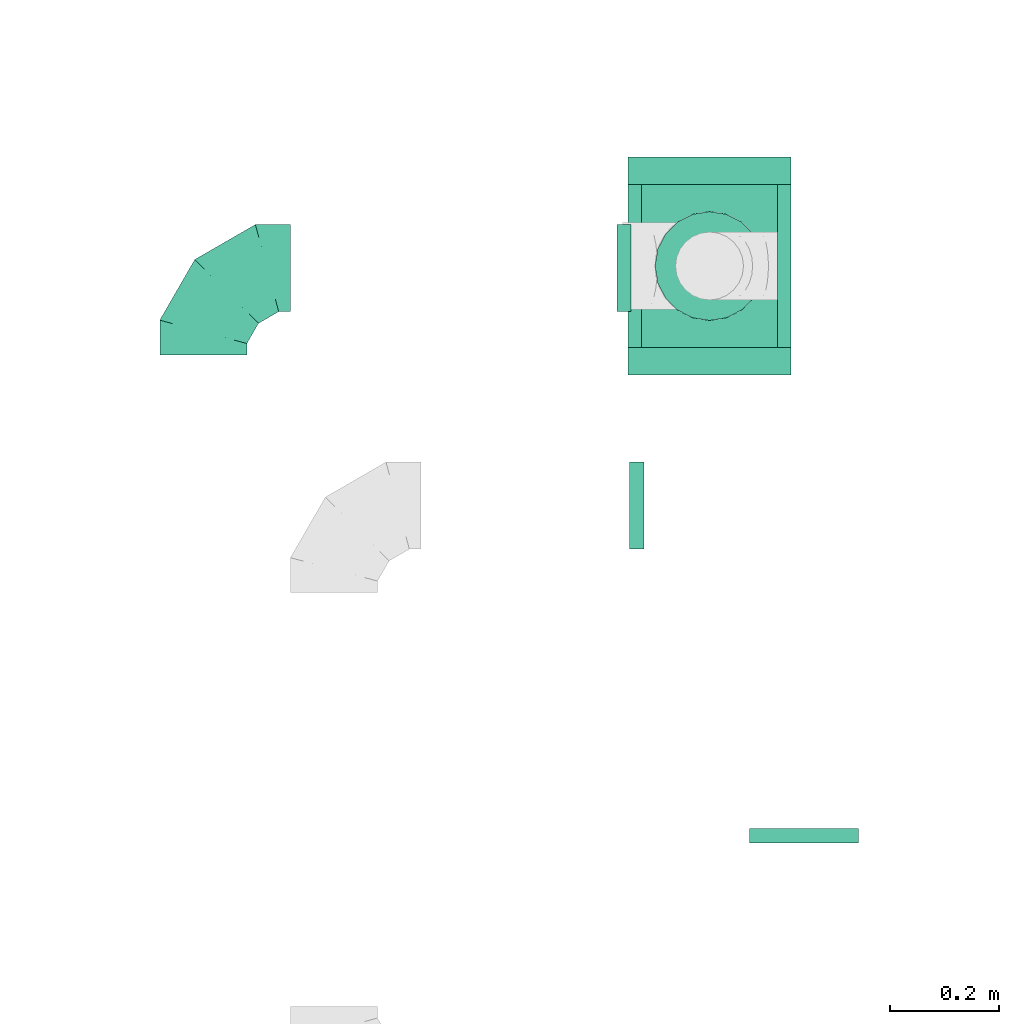
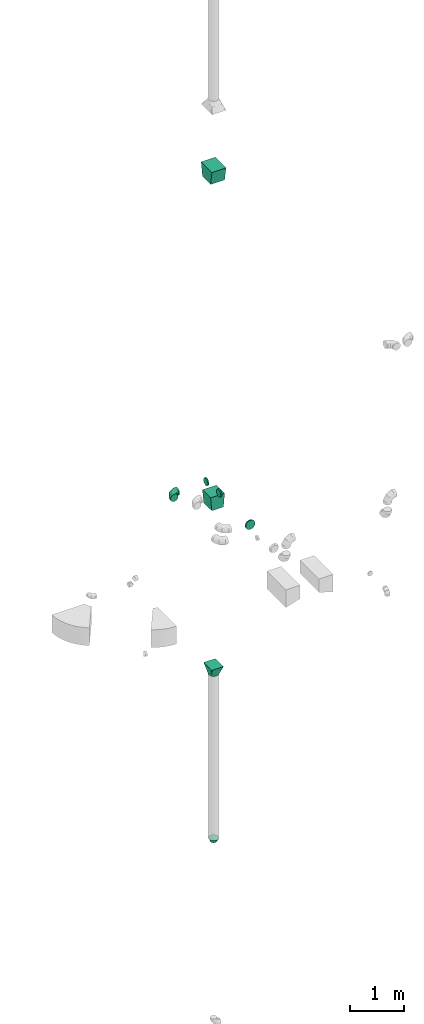
# One storey, part 3 of 32: 8 flow fittings.
"""IFC2X3 building model written with IfcOpenShell, lengths in millimetres."""

from ifc_helpers import new_model, entity, si_unit, converted_unit, derived_unit, direction, frame, origin, place, context, subcontext, project, spatial, polyline, outline, extrude, faceted_brep, source, transform, mapped, material, type_object, type_shapes, element, save


model = new_model("IFC2X3")

# Units and contexts
model_context = context("Model", 3, precision=0.01, world=origin(), true_north=direction((6.12303176911189e-17, 1.0)))
body_context = subcontext(model_context, "Body", "Model", "MODEL_VIEW")
ifc_project = project(units=[si_unit("LENGTHUNIT", "METRE", prefix="MILLI"), si_unit("AREAUNIT", "SQUARE_METRE"), si_unit("VOLUMEUNIT", "CUBIC_METRE"), converted_unit("PLANEANGLEUNIT", "DEGREE", entity("IfcRatioMeasure", 0.0174532925199433), si_unit("PLANEANGLEUNIT", "RADIAN"), dimensions=[0, 0, 0, 0, 0, 0, 0]), si_unit("MASSUNIT", "GRAM", prefix="KILO"), derived_unit("MASSDENSITYUNIT", [(si_unit("MASSUNIT", "GRAM", prefix="KILO"), 1), (si_unit("LENGTHUNIT", "METRE"), -3)]), derived_unit("MOMENTOFINERTIAUNIT", [(si_unit("LENGTHUNIT", "METRE"), 4)]), si_unit("TIMEUNIT", "SECOND"), si_unit("FREQUENCYUNIT", "HERTZ"), si_unit("THERMODYNAMICTEMPERATUREUNIT", "DEGREE_CELSIUS"), derived_unit("THERMALTRANSMITTANCEUNIT", [(si_unit("MASSUNIT", "GRAM", prefix="KILO"), 1), (si_unit("THERMODYNAMICTEMPERATUREUNIT", "KELVIN"), -1), (si_unit("TIMEUNIT", "SECOND"), -3)]), derived_unit("VOLUMETRICFLOWRATEUNIT", [(si_unit("LENGTHUNIT", "METRE"), 3), (si_unit("TIMEUNIT", "SECOND"), -1)]), derived_unit("MASSFLOWRATEUNIT", [(si_unit("MASSUNIT", "GRAM", prefix="KILO"), 1), (si_unit("TIMEUNIT", "SECOND"), -1)]), derived_unit("ROTATIONALFREQUENCYUNIT", [(si_unit("TIMEUNIT", "SECOND"), -1)]), si_unit("ELECTRICCURRENTUNIT", "AMPERE"), si_unit("ELECTRICVOLTAGEUNIT", "VOLT"), si_unit("POWERUNIT", "WATT"), si_unit("FORCEUNIT", "NEWTON", prefix="KILO"), si_unit("ILLUMINANCEUNIT", "LUX"), si_unit("LUMINOUSFLUXUNIT", "LUMEN"), si_unit("LUMINOUSINTENSITYUNIT", "CANDELA"), derived_unit("USERDEFINED", [(si_unit("MASSUNIT", "GRAM", prefix="KILO"), -1), (si_unit("LENGTHUNIT", "METRE"), -2), (si_unit("TIMEUNIT", "SECOND"), 3), (si_unit("LUMINOUSFLUXUNIT", "LUMEN"), 1)]), derived_unit("LINEARVELOCITYUNIT", [(si_unit("LENGTHUNIT", "METRE"), 1), (si_unit("TIMEUNIT", "SECOND"), -1)]), si_unit("PRESSUREUNIT", "PASCAL"), derived_unit("USERDEFINED", [(si_unit("LENGTHUNIT", "METRE"), -2), (si_unit("MASSUNIT", "GRAM", prefix="KILO"), 1), (si_unit("TIMEUNIT", "SECOND"), -2)]), derived_unit("LINEARFORCEUNIT", [(si_unit("MASSUNIT", "GRAM", prefix="KILO"), 1), (si_unit("LENGTHUNIT", "METRE"), 1), (si_unit("TIMEUNIT", "SECOND"), -2), (si_unit("LENGTHUNIT", "METRE"), -1)]), derived_unit("PLANARFORCEUNIT", [(si_unit("MASSUNIT", "GRAM", prefix="KILO"), 1), (si_unit("LENGTHUNIT", "METRE"), 1), (si_unit("TIMEUNIT", "SECOND"), -2), (si_unit("LENGTHUNIT", "METRE"), -2)])], contexts=[model_context])

# Site, building, storey
site_placement = place(None, origin())
site = spatial("IfcSite", under=ifc_project, at=site_placement, CompositionType="ELEMENT")
building_placement = place(site_placement, origin())
building = spatial("IfcBuilding", under=site, at=building_placement, CompositionType="ELEMENT")
storey_placement = place(building_placement, frame((0.0, 0.0, 8100.0)))
storey = spatial("IfcBuildingStorey", under=building, at=storey_placement, CompositionType="ELEMENT", Elevation=8100.0)

# Flow fittings
ifc_material = material()
duct_fitting_type_1 = type_object("IfcDuctFittingType", PredefinedType="NOTDEFINED", material=ifc_material)
shared_shape_1 = source(origin(), body_context, "Body", "SweptSolid", [
    extrude(outline(polyline([(-161.94, -137.02), (139.1, -137.02), (159.86, 112.11), (-137.02, 161.94), (-161.94, -137.02)])), frame((150.0, -150.0, 0.0), z_axis=(0.0, 1.0, 0.0), x_axis=(0.996545254853089, 0.0, -0.0830515203340174)), (0.0, 0.0, 1.0), 300.0),
])
type_shapes(duct_fitting_type_1, [shared_shape_1])
flow_fitting_1_placement = place(storey_placement, frame((8023.56, 14800.47, 3070.0), z_axis=(-1.0, 0.0, 0.0), x_axis=(0.0, 0.0, -1.0)))
element("IfcFlowFitting", 1, at=flow_fitting_1_placement, inside=storey, type_object=duct_fitting_type_1, material=ifc_material, context=body_context, shape_type="MappedRepresentation", body=[
    mapped(shared_shape_1, transform((0.0, 0.0, 0.0), scale=1.0)),
])
duct_fitting_type_2 = type_object("IfcDuctFittingType", PredefinedType="NOTDEFINED", material=ifc_material)
shared_shape_2 = source(origin(), body_context, "Body", "SweptSolid", [
    extrude(outline(polyline([(-123.3, -172.62), (180.84, -172.62), (115.08, 221.94), (-172.62, 123.3), (-123.3, -172.62)])), frame((150.0, 0.0, -150.0), z_axis=(0.0, 0.0, 1.0), x_axis=(0.986393923832143, -0.164398987305359, 0.0)), (0.0, 0.0, 1.0), 300.0),
])
type_shapes(duct_fitting_type_2, [shared_shape_2])
flow_fitting_2_placement = place(storey_placement, frame((8023.56, 14800.47, 10130.0), z_axis=(-1.0, 0.0, 0.0), x_axis=(0.0, 0.0, 1.0)))
element("IfcFlowFitting", 2, at=flow_fitting_2_placement, inside=storey, type_object=duct_fitting_type_2, material=ifc_material, context=body_context, shape_type="MappedRepresentation", body=[
    mapped(shared_shape_2, transform((0.0, 0.0, 0.0), scale=1.0)),
])
duct_fitting_type_3 = type_object("IfcDuctFittingType", PredefinedType="NOTDEFINED", material=ifc_material)
shared_shape_3 = source(origin(), body_context, "Body", "Brep", [
    faceted_brep([(-160.0, 0.0, -80.0), (-160.0, -20.71, -77.27), (-160.0, -40.0, -69.28), (-160.0, -56.57, -56.57), (-160.0, -69.28, -40.0), (-160.0, -77.27, -20.71), (-160.0, -80.0, 0.0), (-160.0, -77.27, 20.71), (-160.0, -69.28, 40.0), (-160.0, -56.57, 56.57), (-160.0, -40.0, 69.28), (-160.0, -20.71, 77.27), (-160.0, 0.0, 80.0), (-160.0, 20.71, 77.27), (-160.0, 40.0, 69.28), (-160.0, 56.57, 56.57), (-160.0, 69.28, 40.0), (-160.0, 77.27, 20.71), (-160.0, 80.0, 0.0), (-160.0, 77.27, -20.71), (-160.0, 69.28, -40.0), (-160.0, 56.57, -56.57), (-160.0, 40.0, -69.28), (-160.0, 20.71, -77.27), (-122.68, 20.71, 77.27), (-127.85, 40.0, 69.28), (-117.13, 0.0, 80.0), (-132.29, 56.57, 56.57), (-137.83, 77.27, 20.71), (-138.56, 80.0, 0.0), (-135.69, 69.28, 40.0), (-135.69, 69.28, -40.0), (-132.29, 56.57, -56.57), (-137.83, 77.27, -20.71), (-122.68, 20.71, -77.27), (-117.13, 0.0, -80.0), (-127.85, 40.0, -69.28), (-111.58, -20.71, -77.27), (-106.41, -40.0, -69.28), (-101.97, -56.57, -56.57), (-98.56, -69.28, -40.0), (-96.42, -77.27, -20.71), (-95.69, -80.0, 0.0), (-96.42, -77.27, 20.71), (-98.56, -69.28, 40.0), (-101.97, -56.57, 56.57), (-106.41, -40.0, 69.28), (-111.58, -20.71, 77.27), (-58.03, 58.03, 77.27), (-72.15, 72.15, 69.28), (-42.87, 42.87, 80.0), (-84.28, 84.28, 56.57), (-93.59, 93.59, 40.0), (-99.44, 99.44, 20.71), (-101.44, 101.44, 0.0), (-99.44, 99.44, -20.71), (-93.59, 93.59, -40.0), (-84.28, 84.28, -56.57), (-58.03, 58.03, -77.27), (-42.87, 42.87, -80.0), (-72.15, 72.15, -69.28), (-27.71, 27.71, -77.27), (-13.59, 13.59, -69.28), (-1.46, 1.46, -56.57), (7.85, -7.85, -40.0), (13.7, -13.7, -20.71), (15.69, -15.69, 0.0), (13.7, -13.7, 20.71), (7.85, -7.85, 40.0), (-1.46, 1.46, 56.57), (-13.59, 13.59, 69.28), (-27.71, 27.71, 77.27), (-20.71, 122.68, 77.27), (-40.0, 127.85, 69.28), (0.0, 117.13, 80.0), (-56.57, 132.29, 56.57), (-69.28, 135.69, 40.0), (-77.27, 137.83, 20.71), (-80.0, 138.56, 0.0), (-77.27, 137.83, -20.71), (-69.28, 135.69, -40.0), (-56.57, 132.29, -56.57), (-20.71, 122.68, -77.27), (0.0, 117.13, -80.0), (-40.0, 127.85, -69.28), (20.71, 111.58, -77.27), (40.0, 106.41, -69.28), (56.57, 101.97, -56.57), (69.28, 98.56, -40.0), (77.27, 96.42, -20.71), (80.0, 95.69, 0.0), (77.27, 96.42, 20.71), (69.28, 98.56, 40.0), (56.57, 101.97, 56.57), (40.0, 106.41, 69.28), (20.71, 111.58, 77.27), (-20.71, 160.0, -77.27), (-40.0, 160.0, -69.28), (-56.57, 160.0, -56.57), (-69.28, 160.0, -40.0), (-77.27, 160.0, -20.71), (-80.0, 160.0, 0.0), (-77.27, 160.0, 20.71), (-69.28, 160.0, 40.0), (-56.57, 160.0, 56.57), (-40.0, 160.0, 69.28), (-20.71, 160.0, 77.27), (0.0, 160.0, 80.0), (20.71, 160.0, 77.27), (40.0, 160.0, 69.28), (56.57, 160.0, 56.57), (69.28, 160.0, 40.0), (77.27, 160.0, 20.71), (80.0, 160.0, 0.0), (77.27, 160.0, -20.71), (69.28, 160.0, -40.0), (56.57, 160.0, -56.57), (40.0, 160.0, -69.28), (20.71, 160.0, -77.27), (0.0, 160.0, -80.0)], [[[0, 1, 2, 3, 4, 5, 6, 7, 8, 9, 10, 11, 12, 13, 14, 15, 16, 17, 18, 19, 20, 21, 22, 23]], [[24, 25, 14, 13]], [[26, 24, 13, 12]], [[14, 25, 27, 15]], [[28, 29, 18, 17]], [[30, 28, 17, 16]], [[15, 27, 30, 16]], [[20, 31, 32, 21]], [[33, 31, 20, 19]], [[18, 29, 33, 19]], [[34, 35, 0, 23]], [[36, 34, 23, 22]], [[32, 36, 22, 21]], [[1, 0, 35, 37]], [[2, 1, 37, 38]], [[3, 2, 38, 39]], [[5, 4, 40, 41]], [[6, 5, 41, 42]], [[39, 40, 4, 3]], [[6, 42, 43, 7]], [[7, 43, 44, 8]], [[8, 44, 45, 9]], [[9, 45, 46, 10]], [[10, 46, 47, 11]], [[26, 12, 11, 47]], [[48, 49, 25, 24]], [[50, 48, 24, 26]], [[27, 25, 49, 51]], [[52, 53, 28, 30]], [[51, 52, 30, 27]], [[29, 28, 53, 54]], [[55, 56, 31, 33]], [[54, 55, 33, 29]], [[32, 31, 56, 57]], [[58, 59, 35, 34]], [[60, 58, 34, 36]], [[57, 60, 36, 32]], [[37, 35, 59, 61]], [[38, 37, 61, 62]], [[39, 38, 62, 63]], [[41, 40, 64, 65]], [[42, 41, 65, 66]], [[63, 64, 40, 39]], [[43, 42, 66, 67]], [[44, 43, 67, 68]], [[68, 69, 45, 44]], [[46, 45, 69, 70]], [[47, 46, 70, 71]], [[26, 47, 71, 50]], [[72, 73, 49, 48]], [[74, 72, 48, 50]], [[51, 49, 73, 75]], [[76, 77, 53, 52]], [[75, 76, 52, 51]], [[54, 53, 77, 78]], [[79, 80, 56, 55]], [[78, 79, 55, 54]], [[57, 56, 80, 81]], [[82, 83, 59, 58]], [[84, 82, 58, 60]], [[81, 84, 60, 57]], [[61, 59, 83, 85]], [[62, 61, 85, 86]], [[63, 62, 86, 87]], [[65, 64, 88, 89]], [[66, 65, 89, 90]], [[87, 88, 64, 63]], [[67, 66, 90, 91]], [[68, 67, 91, 92]], [[92, 93, 69, 68]], [[70, 69, 93, 94]], [[71, 70, 94, 95]], [[50, 71, 95, 74]], [[96, 97, 98, 99, 100, 101, 102, 103, 104, 105, 106, 107, 108, 109, 110, 111, 112, 113, 114, 115, 116, 117, 118, 119]], [[72, 74, 107, 106]], [[73, 72, 106, 105]], [[75, 73, 105, 104]], [[77, 76, 103, 102]], [[78, 77, 102, 101]], [[75, 104, 103, 76]], [[78, 101, 100, 79]], [[79, 100, 99, 80]], [[80, 99, 98, 81]], [[84, 97, 96, 82]], [[82, 96, 119, 83]], [[84, 81, 98, 97]], [[118, 117, 86, 85]], [[119, 118, 85, 83]], [[116, 87, 86, 117]], [[88, 115, 114, 89]], [[89, 114, 113, 90]], [[115, 88, 87, 116]], [[112, 111, 92, 91]], [[113, 112, 91, 90]], [[111, 110, 93, 92]], [[95, 94, 109, 108]], [[74, 95, 108, 107]], [[110, 109, 94, 93]]]),
])
type_shapes(duct_fitting_type_3, [shared_shape_3])
flow_fitting_3_placement = place(storey_placement, frame((7093.56, 14796.64, 3350.0), z_axis=(0.0, 0.0, 1.0), x_axis=(-1.0, 0.0, 0.0)))
element("IfcFlowFitting", 3, at=flow_fitting_3_placement, inside=storey, type_object=duct_fitting_type_3, material=ifc_material, context=body_context, shape_type="MappedRepresentation", body=[
    mapped(shared_shape_3, transform((0.0, 0.0, 0.0), scale=1.0)),
])
duct_fitting_type_4 = type_object("IfcDuctFittingType", PredefinedType="NOTDEFINED", material=ifc_material)
shared_shape_4 = source(origin(), body_context, "Body", "Brep", [
    faceted_brep([(75.0, -57.74, 23.92), (75.0, -60.12, 11.96), (75.0, -62.5, 0.0), (75.0, -60.12, -11.96), (75.0, -57.74, -23.92), (75.0, -50.97, -34.06), (75.0, -44.19, -44.19), (75.0, -34.06, -50.97), (75.0, -23.92, -57.74), (75.0, -11.96, -60.12), (75.0, 0.0, -62.5), (75.0, 11.96, -60.12), (75.0, 23.92, -57.74), (75.0, 34.06, -50.97), (75.0, 44.19, -44.19), (75.0, 50.97, -34.06), (75.0, 57.74, -23.92), (75.0, 60.12, -11.96), (75.0, 62.5, 0.0), (75.0, 60.12, 11.96), (75.0, 57.74, 23.92), (75.0, 50.97, 34.06), (75.0, 44.19, 44.19), (75.0, 34.06, 50.97), (75.0, 23.92, 57.74), (75.0, 11.96, 60.12), (75.0, 0.0, 62.5), (75.0, -11.96, 60.12), (75.0, -23.92, 57.74), (75.0, -34.06, 50.97), (75.0, -44.19, 44.19), (75.0, -50.97, 34.06), (0.0, -100.0, 0.0), (0.0, -95.11, 30.9), (0.0, -80.9, 58.78), (0.0, -58.78, 80.9), (0.0, -30.9, 95.11), (0.0, 0.0, 100.0), (0.0, 30.9, 95.11), (0.0, 58.78, 80.9), (0.0, 80.9, 58.78), (0.0, 95.11, 30.9), (0.0, 100.0, 0.0), (0.0, 95.11, -30.9), (0.0, 80.9, -58.78), (0.0, 58.78, -80.9), (0.0, 30.9, -95.11), (0.0, 0.0, -100.0), (0.0, -30.9, -95.11), (0.0, -58.78, -80.9), (0.0, -80.9, -58.78), (0.0, -95.11, -30.9)], [[[0, 1, 2, 3, 4, 5, 6, 7, 8, 9, 10, 11, 12, 13, 14, 15, 16, 17, 18, 19, 20, 21, 22, 23, 24, 25, 26, 27, 28, 29, 30, 31]], [[32, 33, 34, 35, 36, 37, 38, 39, 40, 41, 42, 43, 44, 45, 46, 47, 48, 49, 50, 51]], [[37, 25, 38]], [[41, 20, 19]], [[24, 39, 38]], [[40, 22, 21, 20]], [[23, 22, 39, 24]], [[18, 42, 19]], [[25, 24, 38]], [[40, 20, 41]], [[19, 42, 41]], [[25, 37, 26]], [[22, 40, 39]], [[32, 1, 33]], [[36, 28, 27]], [[0, 34, 33]], [[35, 30, 29, 28]], [[31, 30, 34, 0]], [[26, 37, 27]], [[1, 0, 33]], [[35, 28, 36]], [[27, 37, 36]], [[1, 32, 2]], [[30, 35, 34]], [[47, 9, 48]], [[51, 4, 3]], [[8, 49, 48]], [[50, 6, 5, 4]], [[7, 6, 49, 8]], [[2, 32, 3]], [[9, 8, 48]], [[50, 4, 51]], [[3, 32, 51]], [[9, 47, 10]], [[6, 50, 49]], [[42, 17, 43]], [[46, 12, 11]], [[16, 44, 43]], [[45, 14, 13, 12]], [[15, 14, 44, 16]], [[10, 47, 11]], [[17, 16, 43]], [[45, 12, 46]], [[11, 47, 46]], [[17, 42, 18]], [[14, 45, 44]]]),
])
type_shapes(duct_fitting_type_4, [shared_shape_4])
flow_fitting_4_placement = place(storey_placement, frame((8023.54, 14800.39, -4730.0), z_axis=(-1.0, 0.0, 0.0), x_axis=(0.0, 0.0, -1.0)))
element("IfcFlowFitting", 4, at=flow_fitting_4_placement, inside=storey, type_object=duct_fitting_type_4, material=ifc_material, context=body_context, shape_type="MappedRepresentation", body=[
    mapped(shared_shape_4, transform((0.0, 0.0, 0.0), scale=1.0)),
])
duct_fitting_type_5 = type_object("IfcDuctFittingType", PredefinedType="NOTDEFINED", material=ifc_material)
shared_shape_5 = source(origin(), body_context, "Body", "Brep", [
    faceted_brep([(20.0, 25.88, -96.59), (20.0, 50.0, -86.6), (20.0, 70.71, -70.71), (20.0, 86.6, -50.0), (20.0, 96.59, -25.88), (20.0, 100.0, 0.0), (20.0, 96.59, 25.88), (20.0, 86.6, 50.0), (20.0, 70.71, 70.71), (20.0, 50.0, 86.6), (20.0, 25.88, 96.59), (20.0, 0.0, 100.0), (20.0, -25.88, 96.59), (20.0, -50.0, 86.6), (20.0, -70.71, 70.71), (20.0, -86.6, 50.0), (20.0, -96.59, 25.88), (20.0, -100.0, 0.0), (20.0, -96.59, -25.88), (20.0, -86.6, -50.0), (20.0, -70.71, -70.71), (20.0, -50.0, -86.6), (20.0, -25.88, -96.59), (20.0, 0.0, -100.0), (0.0, 0.0, 100.0), (0.0, 25.88, 96.59), (-6.1, 25.88, 96.59), (-6.1, 0.0, 100.0), (0.0, 50.0, 86.6), (-6.1, 50.0, 86.6), (0.0, 70.71, 70.71), (-6.1, 70.71, 70.71), (0.0, 86.6, 50.0), (0.0, 96.59, 25.88), (-6.1, 96.59, 25.88), (-6.1, 86.6, 50.0), (0.0, 100.0, 0.0), (-6.1, 100.0, 0.0), (0.0, 96.59, -25.88), (-6.1, 96.59, -25.88), (0.0, 86.6, -50.0), (-6.1, 86.6, -50.0), (0.0, 70.71, -70.71), (-6.1, 70.71, -70.71), (0.0, 50.0, -86.6), (0.0, 25.88, -96.59), (-6.1, 25.88, -96.59), (-6.1, 50.0, -86.6), (0.0, 0.0, -100.0), (-6.1, 0.0, -100.0), (0.0, -25.88, -96.59), (-6.1, -25.88, -96.59), (0.0, -50.0, -86.6), (-6.1, -50.0, -86.6), (0.0, -70.71, -70.71), (-6.1, -70.71, -70.71), (0.0, -86.6, -50.0), (0.0, -96.59, -25.88), (-6.1, -96.59, -25.88), (-6.1, -86.6, -50.0), (0.0, -100.0, 0.0), (-6.1, -100.0, 0.0), (0.0, -96.59, 25.88), (-6.1, -96.59, 25.88), (0.0, -86.6, 50.0), (-6.1, -86.6, 50.0), (0.0, -70.71, 70.71), (-6.1, -70.71, 70.71), (0.0, -50.0, 86.6), (0.0, -25.88, 96.59), (-6.1, -25.88, 96.59), (-6.1, -50.0, 86.6)], [[[0, 1, 2, 3, 4, 5, 6, 7, 8, 9, 10, 11, 12, 13, 14, 15, 16, 17, 18, 19, 20, 21, 22, 23]], [[24, 11, 10, 25, 26, 27]], [[25, 10, 9, 28, 29, 26]], [[28, 9, 8, 30, 31, 29]], [[32, 7, 6, 33, 34, 35]], [[33, 6, 5, 36, 37, 34]], [[30, 8, 7, 32, 35, 31]], [[36, 5, 4, 38, 39, 37]], [[38, 4, 3, 40, 41, 39]], [[40, 3, 2, 42, 43, 41]], [[44, 1, 0, 45, 46, 47]], [[45, 0, 23, 48, 49, 46]], [[42, 2, 1, 44, 47, 43]], [[48, 23, 22, 50, 51, 49]], [[50, 22, 21, 52, 53, 51]], [[52, 21, 20, 54, 55, 53]], [[56, 19, 18, 57, 58, 59]], [[57, 18, 17, 60, 61, 58]], [[54, 20, 19, 56, 59, 55]], [[60, 17, 16, 62, 63, 61]], [[62, 16, 15, 64, 65, 63]], [[64, 15, 14, 66, 67, 65]], [[68, 13, 12, 69, 70, 71]], [[69, 12, 11, 24, 27, 70]], [[66, 14, 13, 68, 71, 67]], [[49, 51, 53, 55, 59, 58, 61, 63, 65, 67, 71, 70, 27, 26, 29, 31, 35, 34, 37, 39, 41, 43, 47, 46]]]),
])
type_shapes(duct_fitting_type_5, [shared_shape_5])
flow_fitting_5_placement = place(storey_placement, frame((8197.33, 13760.69, 2900.0), z_axis=(-1.0, 0.0, 0.0), x_axis=(0.0, -1.0, 0.0)))
element("IfcFlowFitting", 5, at=flow_fitting_5_placement, inside=storey, type_object=duct_fitting_type_5, material=ifc_material, context=body_context, shape_type="MappedRepresentation", body=[
    mapped(shared_shape_5, transform((0.0, 0.0, 0.0), scale=1.0)),
])
duct_fitting_type_6 = type_object("IfcDuctFittingType", PredefinedType="NOTDEFINED", material=ifc_material)
shared_shape_6 = source(origin(), body_context, "Body", "Brep", [
    faceted_brep([(20.0, 20.71, -77.27), (20.0, 40.0, -69.28), (20.0, 56.57, -56.57), (20.0, 69.28, -40.0), (20.0, 77.27, -20.71), (20.0, 80.0, 0.0), (20.0, 77.27, 20.71), (20.0, 69.28, 40.0), (20.0, 56.57, 56.57), (20.0, 40.0, 69.28), (20.0, 20.71, 77.27), (20.0, 0.0, 80.0), (20.0, -20.71, 77.27), (20.0, -40.0, 69.28), (20.0, -56.57, 56.57), (20.0, -69.28, 40.0), (20.0, -77.27, 20.71), (20.0, -80.0, 0.0), (20.0, -77.27, -20.71), (20.0, -69.28, -40.0), (20.0, -56.57, -56.57), (20.0, -40.0, -69.28), (20.0, -20.71, -77.27), (20.0, 0.0, -80.0), (0.0, 0.0, 80.0), (0.0, 20.71, 77.27), (-6.1, 20.71, 77.27), (-6.1, 0.0, 80.0), (0.0, 40.0, 69.28), (-6.1, 40.0, 69.28), (0.0, 56.57, 56.57), (-6.1, 56.57, 56.57), (0.0, 69.28, 40.0), (0.0, 77.27, 20.71), (-6.1, 77.27, 20.71), (-6.1, 69.28, 40.0), (0.0, 80.0, 0.0), (-6.1, 80.0, 0.0), (0.0, 77.27, -20.71), (-6.1, 77.27, -20.71), (0.0, 69.28, -40.0), (-6.1, 69.28, -40.0), (0.0, 56.57, -56.57), (-6.1, 56.57, -56.57), (0.0, 40.0, -69.28), (0.0, 20.71, -77.27), (-6.1, 20.71, -77.27), (-6.1, 40.0, -69.28), (0.0, 0.0, -80.0), (-6.1, 0.0, -80.0), (0.0, -20.71, -77.27), (-6.1, -20.71, -77.27), (0.0, -40.0, -69.28), (-6.1, -40.0, -69.28), (0.0, -56.57, -56.57), (-6.1, -56.57, -56.57), (0.0, -69.28, -40.0), (0.0, -77.27, -20.71), (-6.1, -77.27, -20.71), (-6.1, -69.28, -40.0), (0.0, -80.0, 0.0), (-6.1, -80.0, 0.0), (0.0, -77.27, 20.71), (-6.1, -77.27, 20.71), (0.0, -69.28, 40.0), (-6.1, -69.28, 40.0), (0.0, -56.57, 56.57), (-6.1, -56.57, 56.57), (0.0, -40.0, 69.28), (0.0, -20.71, 77.27), (-6.1, -20.71, 77.27), (-6.1, -40.0, 69.28)], [[[0, 1, 2, 3, 4, 5, 6, 7, 8, 9, 10, 11, 12, 13, 14, 15, 16, 17, 18, 19, 20, 21, 22, 23]], [[24, 11, 10, 25, 26, 27]], [[25, 10, 9, 28, 29, 26]], [[28, 9, 8, 30, 31, 29]], [[32, 7, 6, 33, 34, 35]], [[33, 6, 5, 36, 37, 34]], [[30, 8, 7, 32, 35, 31]], [[36, 5, 4, 38, 39, 37]], [[38, 4, 3, 40, 41, 39]], [[40, 3, 2, 42, 43, 41]], [[44, 1, 0, 45, 46, 47]], [[45, 0, 23, 48, 49, 46]], [[42, 2, 1, 44, 47, 43]], [[48, 23, 22, 50, 51, 49]], [[50, 22, 21, 52, 53, 51]], [[52, 21, 20, 54, 55, 53]], [[56, 19, 18, 57, 58, 59]], [[57, 18, 17, 60, 61, 58]], [[54, 20, 19, 56, 59, 55]], [[60, 17, 16, 62, 63, 61]], [[62, 16, 15, 64, 65, 63]], [[64, 15, 14, 66, 67, 65]], [[68, 13, 12, 69, 70, 71]], [[69, 12, 11, 24, 27, 70]], [[66, 14, 13, 68, 71, 67]], [[49, 51, 53, 55, 59, 58, 61, 63, 65, 67, 71, 70, 27, 26, 29, 31, 35, 34, 37, 39, 41, 43, 47, 46]]]),
])
type_shapes(duct_fitting_type_6, [shared_shape_6])
for number, where, z_axis, x_axis in (
    (6, (7873.56, 14796.72, 3350.0), (0.0, 1.0, 0.0), (-1.0, 0.0, 0.0)),
    (7, (7896.67, 14360.27, 3350.0), (0.0, 1.0, 0.0), (-1.0, 0.0, 0.0)),
):
    element("IfcFlowFitting", number, at=place(storey_placement, frame(where, z_axis=z_axis, x_axis=x_axis)), inside=storey, type_object=duct_fitting_type_6, material=ifc_material, context=body_context, shape_type="MappedRepresentation", body=[
        mapped(shared_shape_6, transform((0.0, 0.0, 0.0), scale=1.0)),
    ])
duct_fitting_type_7 = type_object("IfcDuctFittingType", PredefinedType="NOTDEFINED", material=ifc_material)
shared_shape_7 = source(origin(), body_context, "Body", "Brep", [
    faceted_brep([(200.0, 30.9, 95.11), (200.0, 19.08, 96.98), (200.0, 9.54, 98.49), (200.0, 4.77, 99.24), (200.0, 0.0, 100.0), (200.0, -4.77, 99.24), (200.0, -9.54, 98.49), (200.0, -19.08, 96.98), (200.0, -30.9, 95.11), (200.0, -44.84, 88.0), (200.0, -58.78, 80.9), (200.0, -69.84, 69.84), (200.0, -80.9, 58.78), (200.0, -88.0, 44.84), (200.0, -95.11, 30.9), (200.0, -96.98, 19.08), (200.0, -98.49, 9.54), (200.0, -99.24, 4.77), (200.0, -100.0, 0.0), (200.0, -99.24, -4.77), (200.0, -98.49, -9.54), (200.0, -96.98, -19.08), (200.0, -95.11, -30.9), (200.0, -88.0, -44.84), (200.0, -80.9, -58.78), (200.0, -69.84, -69.84), (200.0, -58.78, -80.9), (200.0, -44.84, -88.0), (200.0, -30.9, -95.11), (200.0, -19.08, -96.98), (200.0, -9.54, -98.49), (200.0, -4.77, -99.24), (200.0, 0.0, -100.0), (200.0, 4.77, -99.24), (200.0, 9.54, -98.49), (200.0, 19.08, -96.98), (200.0, 30.9, -95.11), (200.0, 44.84, -88.0), (200.0, 58.78, -80.9), (200.0, 69.84, -69.84), (200.0, 80.9, -58.78), (200.0, 88.0, -44.84), (200.0, 95.11, -30.9), (200.0, 96.98, -19.08), (200.0, 98.49, -9.54), (200.0, 99.24, -4.77), (200.0, 100.0, 0.0), (200.0, 99.24, 4.77), (200.0, 98.49, 9.54), (200.0, 96.98, 19.08), (200.0, 95.11, 30.9), (200.0, 88.0, 44.84), (200.0, 80.9, 58.78), (200.0, 69.84, 69.84), (200.0, 58.78, 80.9), (200.0, 44.84, 88.0), (0.0, -150.0, 125.0), (0.0, 150.0, 125.0), (0.0, 150.0, -125.0), (0.0, -150.0, -125.0), (104.11, -71.91, 111.99), (100.0, -108.15, 99.93), (26.03, -130.48, 121.75), (78.09, -91.44, 115.24), (52.06, -110.96, 118.49), (188.01, -8.99, 101.5), (176.03, -17.98, 103.0), (152.06, -35.96, 105.99), (128.09, -53.94, 108.99), (52.06, -136.99, 92.46), (78.09, -130.48, 76.2), (104.11, -123.97, 59.93), (128.09, -117.98, 44.95), (152.06, -111.99, 29.96), (176.03, -105.99, 14.98), (188.01, -103.0, 7.49), (26.03, -143.49, 108.73), (26.03, -143.49, -108.73), (52.06, -136.99, -92.46), (78.09, -130.48, -76.2), (104.11, -123.97, -59.93), (128.09, -117.98, -44.95), (152.06, -111.99, -29.96), (176.03, -105.99, -14.98), (188.01, -103.0, -7.49), (100.0, -112.43, -95.65), (52.06, -110.96, -118.49), (78.09, -91.44, -115.24), (104.11, -71.91, -111.99), (128.09, -53.94, -108.99), (152.06, -35.96, -105.99), (176.03, -17.98, -103.0), (188.01, -8.99, -101.5), (26.03, -130.48, -121.75), (26.03, 130.48, -121.75), (52.06, 110.96, -118.49), (78.09, 91.44, -115.24), (104.11, 71.91, -111.99), (128.09, 53.94, -108.99), (152.06, 35.96, -105.99), (176.03, 17.98, -103.0), (188.01, 8.99, -101.5), (100.0, 108.15, -99.93), (52.06, 136.99, -92.46), (78.09, 130.48, -76.2), (104.11, 123.97, -59.93), (128.09, 117.98, -44.95), (152.06, 111.99, -29.96), (176.03, 105.99, -14.98), (188.01, 103.0, -7.49), (26.03, 143.49, -108.73), (26.03, 143.49, 108.73), (52.06, 136.99, 92.46), (78.09, 130.48, 76.2), (104.11, 123.97, 59.93), (128.09, 117.98, 44.95), (152.06, 111.99, 29.96), (176.03, 105.99, 14.98), (188.01, 103.0, 7.49), (100.0, 112.43, 95.65), (52.06, 110.96, 118.49), (78.09, 91.44, 115.24), (104.11, 71.91, 111.99), (128.09, 53.94, 108.99), (152.06, 35.96, 105.99), (176.03, 17.98, 103.0), (188.01, 8.99, 101.5), (26.03, 130.48, 121.75)], [[[0, 1, 2, 3, 4, 5, 6, 7, 8, 9, 10, 11, 12, 13, 14, 15, 16, 17, 18, 19, 20, 21, 22, 23, 24, 25, 26, 27, 28, 29, 30, 31, 32, 33, 34, 35, 36, 37, 38, 39, 40, 41, 42, 43, 44, 45, 46, 47, 48, 49, 50, 51, 52, 53, 54, 55]], [[56, 57, 58, 59]], [[60, 9, 8]], [[56, 61, 62]], [[9, 60, 63, 64]], [[65, 66, 67, 68, 60, 8, 7, 6, 5, 4]], [[62, 61, 10]], [[13, 69, 70, 71]], [[64, 10, 9]], [[14, 71, 72, 73, 74, 75, 18, 17, 16, 15]], [[12, 76, 69]], [[71, 14, 13]], [[61, 76, 11]], [[10, 64, 62]], [[76, 12, 11]], [[10, 61, 11]], [[61, 56, 76]], [[69, 13, 12]], [[75, 74, 73, 72, 71, 70, 69, 76, 56, 59, 77, 78, 79, 80, 81, 82, 83, 84, 18]], [[80, 23, 22]], [[59, 85, 77]], [[23, 80, 79, 78]], [[84, 83, 82, 81, 80, 22, 21, 20, 19, 18]], [[77, 85, 24]], [[27, 86, 87, 88]], [[78, 24, 23]], [[28, 88, 89, 90, 91, 92, 32, 31, 30, 29]], [[26, 93, 86]], [[88, 28, 27]], [[85, 93, 25]], [[24, 78, 77]], [[93, 26, 25]], [[24, 85, 25]], [[85, 59, 93]], [[86, 27, 26]], [[92, 91, 90, 89, 88, 87, 86, 93, 59, 58, 94, 95, 96, 97, 98, 99, 100, 101, 32]], [[97, 37, 36]], [[58, 102, 94]], [[37, 97, 96, 95]], [[101, 100, 99, 98, 97, 36, 35, 34, 33, 32]], [[94, 102, 38]], [[41, 103, 104, 105]], [[95, 38, 37]], [[42, 105, 106, 107, 108, 109, 46, 45, 44, 43]], [[40, 110, 103]], [[105, 42, 41]], [[102, 110, 39]], [[38, 95, 94]], [[110, 40, 39]], [[38, 102, 39]], [[102, 58, 110]], [[103, 41, 40]], [[58, 57, 111, 112, 113, 114, 115, 116, 117, 118, 46, 109, 108, 107, 106, 105, 104, 103, 110]], [[114, 51, 50]], [[57, 119, 111]], [[51, 114, 113, 112]], [[118, 117, 116, 115, 114, 50, 49, 48, 47, 46]], [[111, 119, 52]], [[55, 120, 121, 122]], [[112, 52, 51]], [[0, 122, 123, 124, 125, 126, 4, 3, 2, 1]], [[54, 127, 120]], [[122, 0, 55]], [[119, 127, 53]], [[52, 112, 111]], [[127, 54, 53]], [[52, 119, 53]], [[119, 57, 127]], [[120, 55, 54]], [[57, 56, 62, 64, 63, 60, 68, 67, 66, 65, 4, 126, 125, 124, 123, 122, 121, 120, 127]]]),
])
type_shapes(duct_fitting_type_7, [shared_shape_7])
flow_fitting_6_placement = place(storey_placement, frame((8023.54, 14800.47, -830.0), z_axis=(-1.0, 0.0, 0.0), x_axis=(0.0, 0.0, -1.0)))
element("IfcFlowFitting", 8, at=flow_fitting_6_placement, inside=storey, type_object=duct_fitting_type_7, material=ifc_material, context=body_context, shape_type="MappedRepresentation", body=[
    mapped(shared_shape_7, transform((0.0, 0.0, 0.0), scale=1.0)),
])

save(model, "model.ifc")
